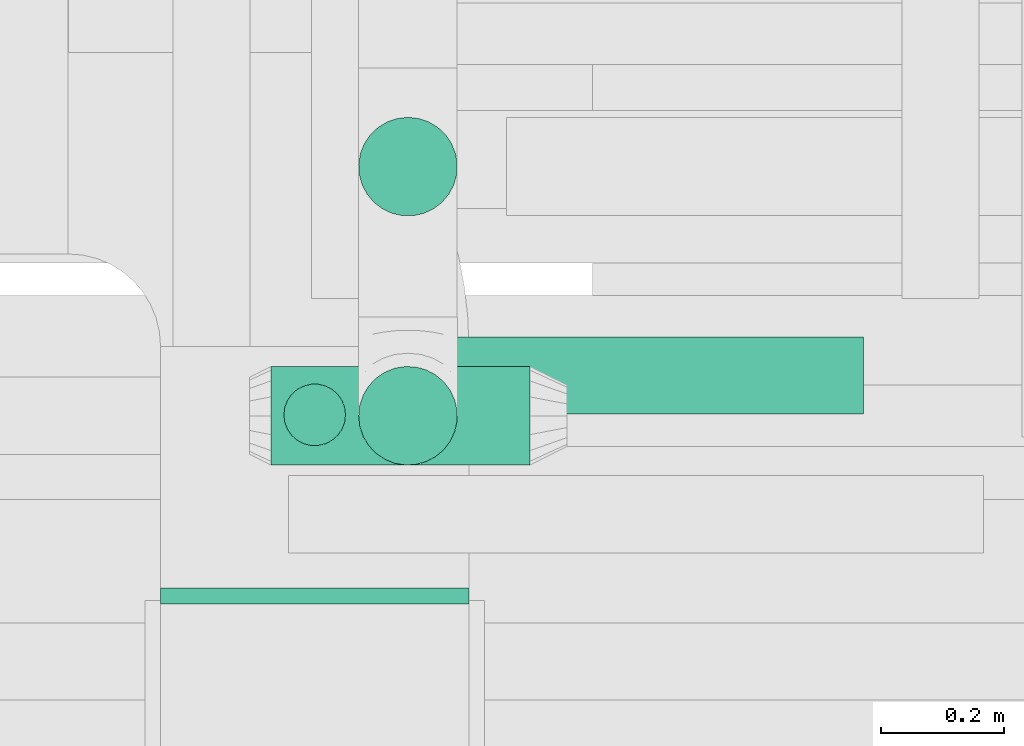
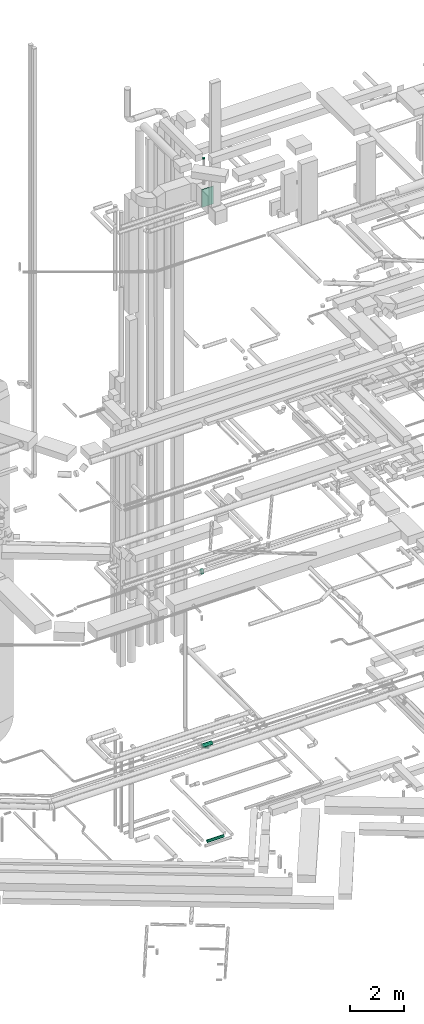
# One storey, part 99 of 337: 4 flow segments, 2 flow fittings.
"""IFC2X3 building model written with IfcOpenShell, lengths in millimetres."""

from ifc_helpers import new_model, entity, si_unit, converted_unit, derived_unit, direction, frame, origin, origin_2d_with_axis, place, context, subcontext, project, spatial, rectangle, circle, extrude, source, transform, mapped, material, type_object, type_shapes, element, save


model = new_model("IFC2X3")

# Units and contexts
model_context = context("Model", 3, precision=0.01, world=origin(), true_north=direction((6.12303176911189e-17, 1.0)))
body_context = subcontext(model_context, "Body", "Model", "MODEL_VIEW")
ifc_project = project(units=[si_unit("LENGTHUNIT", "METRE", prefix="MILLI"), si_unit("AREAUNIT", "SQUARE_METRE"), si_unit("VOLUMEUNIT", "CUBIC_METRE"), converted_unit("PLANEANGLEUNIT", "DEGREE", entity("IfcRatioMeasure", 0.0174532925199433), si_unit("PLANEANGLEUNIT", "RADIAN"), dimensions=[0, 0, 0, 0, 0, 0, 0]), si_unit("MASSUNIT", "GRAM", prefix="KILO"), derived_unit("MASSDENSITYUNIT", [(si_unit("MASSUNIT", "GRAM", prefix="KILO"), 1), (si_unit("LENGTHUNIT", "METRE"), -3)]), derived_unit("MOMENTOFINERTIAUNIT", [(si_unit("LENGTHUNIT", "METRE"), 4)]), si_unit("TIMEUNIT", "SECOND"), si_unit("FREQUENCYUNIT", "HERTZ"), si_unit("THERMODYNAMICTEMPERATUREUNIT", "DEGREE_CELSIUS"), derived_unit("THERMALTRANSMITTANCEUNIT", [(si_unit("MASSUNIT", "GRAM", prefix="KILO"), 1), (si_unit("THERMODYNAMICTEMPERATUREUNIT", "KELVIN"), -1), (si_unit("TIMEUNIT", "SECOND"), -3)]), derived_unit("VOLUMETRICFLOWRATEUNIT", [(si_unit("LENGTHUNIT", "METRE"), 3), (si_unit("TIMEUNIT", "SECOND"), -1)]), derived_unit("MASSFLOWRATEUNIT", [(si_unit("MASSUNIT", "GRAM", prefix="KILO"), 1), (si_unit("TIMEUNIT", "SECOND"), -1)]), derived_unit("ROTATIONALFREQUENCYUNIT", [(si_unit("TIMEUNIT", "SECOND"), -1)]), si_unit("ELECTRICCURRENTUNIT", "AMPERE"), si_unit("ELECTRICVOLTAGEUNIT", "VOLT"), si_unit("POWERUNIT", "WATT"), si_unit("FORCEUNIT", "NEWTON", prefix="KILO"), si_unit("ILLUMINANCEUNIT", "LUX"), si_unit("LUMINOUSFLUXUNIT", "LUMEN"), si_unit("LUMINOUSINTENSITYUNIT", "CANDELA"), derived_unit("USERDEFINED", [(si_unit("MASSUNIT", "GRAM", prefix="KILO"), -1), (si_unit("LENGTHUNIT", "METRE"), -2), (si_unit("TIMEUNIT", "SECOND"), 3), (si_unit("LUMINOUSFLUXUNIT", "LUMEN"), 1)]), derived_unit("LINEARVELOCITYUNIT", [(si_unit("LENGTHUNIT", "METRE"), 1), (si_unit("TIMEUNIT", "SECOND"), -1)]), si_unit("PRESSUREUNIT", "PASCAL"), derived_unit("USERDEFINED", [(si_unit("LENGTHUNIT", "METRE"), -2), (si_unit("MASSUNIT", "GRAM", prefix="KILO"), 1), (si_unit("TIMEUNIT", "SECOND"), -2)]), derived_unit("LINEARFORCEUNIT", [(si_unit("MASSUNIT", "GRAM", prefix="KILO"), 1), (si_unit("LENGTHUNIT", "METRE"), 1), (si_unit("TIMEUNIT", "SECOND"), -2), (si_unit("LENGTHUNIT", "METRE"), -1)]), derived_unit("PLANARFORCEUNIT", [(si_unit("MASSUNIT", "GRAM", prefix="KILO"), 1), (si_unit("LENGTHUNIT", "METRE"), 1), (si_unit("TIMEUNIT", "SECOND"), -2), (si_unit("LENGTHUNIT", "METRE"), -2)])], contexts=[model_context])

# Site, building, storey
site_placement = place(None, origin())
site = spatial("IfcSite", under=ifc_project, at=site_placement, CompositionType="ELEMENT")
building_placement = place(site_placement, origin())
building = spatial("IfcBuilding", under=site, at=building_placement, CompositionType="ELEMENT")
storey_placement = place(building_placement, origin())
storey = spatial("IfcBuildingStorey", under=building, at=storey_placement, CompositionType="ELEMENT", Elevation=0.0)

# Flow segments
duct_segment_type = type_object("IfcDuctSegmentType", PredefinedType="NOTDEFINED")
flow_segment_1_placement = place(storey_placement, frame((10556.19, 12311.66, -864.1)))
element("IfcFlowSegment", 1, at=flow_segment_1_placement, inside=storey, type_object=duct_segment_type, context=body_context, shape_type="SweptSolid", body=[
    extrude(circle(Radius=62.5, at=origin_2d_with_axis()), frame((0.0, 64.1, 64.1), z_axis=(1.0, 0.0, 0.0), x_axis=(0.0, -1.0, 0.0)), (0.0, 0.0, 1.0), 707.394973250135),
])
flow_segment_2_placement = place(storey_placement, frame((10302.78, 12228.76, 3568.4)))
element("IfcFlowSegment", 2, at=flow_segment_2_placement, inside=storey, type_object=duct_segment_type, context=body_context, shape_type="SweptSolid", body=[
    extrude(circle(Radius=80.0, at=origin_2d_with_axis()), frame((0.0, 81.6, 81.6), z_axis=(1.0, 0.0, 0.0), x_axis=(0.0, -1.0, 0.0)), (0.0, 0.0, 1.0), 419.99999999998),
])
flow_segment_3_placement = place(storey_placement, frame((10443.31, 12632.75, 11160.0)))
element("IfcFlowSegment", 3, at=flow_segment_3_placement, inside=storey, type_object=duct_segment_type, context=body_context, shape_type="SweptSolid", body=[
    extrude(circle(Radius=80.0, at=origin_2d_with_axis()), frame((81.6, 81.6, 0.0), z_axis=(0.0, 0.0, 1.0), x_axis=(0.0, 1.0, 0.0)), (0.0, 0.0, 1.0), 150.002722905561),
])
flow_segment_4_placement = place(storey_placement, frame((10443.31, 12228.76, 3480.0)))
element("IfcFlowSegment", 4, at=flow_segment_4_placement, inside=storey, type_object=duct_segment_type, context=body_context, shape_type="SweptSolid", body=[
    extrude(circle(Radius=80.0, at=origin_2d_with_axis()), frame((81.6, 81.6, 0.0), z_axis=(0.0, 0.0, 1.0), x_axis=(-1.0, 0.0, 0.0)), (0.0, 0.0, 1.0), 69.9999999999191),
])

# Flow fittings
ifc_material = material()
duct_fitting_type_1 = type_object("IfcDuctFittingType", PredefinedType="NOTDEFINED", material=ifc_material)
shared_shape_1 = source(origin(), body_context, "Body", "SweptSolid", [
    extrude(circle(Radius=49.9999999999997, at=origin_2d_with_axis()), frame((0.0, 0.0, 0.0), z_axis=(1.0, 0.0, 0.0), x_axis=(0.0, 1.0, 0.0)), (0.0, 0.0, 1.0), 25.0000000000018),
])
type_shapes(duct_fitting_type_1, [shared_shape_1])
flow_fitting_1_placement = place(storey_placement, frame((10373.64, 12311.85, 30250.0), z_axis=(0.0, -1.0, 0.0), x_axis=(0.0, 0.0, 1.0)))
element("IfcFlowFitting", 5, at=flow_fitting_1_placement, inside=storey, type_object=duct_fitting_type_1, material=ifc_material, context=body_context, shape_type="MappedRepresentation", body=[
    mapped(shared_shape_1, transform((0.0, 0.0, 0.0), scale=1.0)),
])
duct_fitting_type_2 = type_object("IfcDuctFittingType", PredefinedType="NOTDEFINED", material=ifc_material)
shared_shape_2 = source(origin(), body_context, "Body", "SweptSolid", [
    extrude(rectangle(XDim=500.0, YDim=26.0960000000953, at=origin_2d_with_axis()), frame((6.95, 0.0, -400.0), z_axis=(0.0, 0.0, 1.0), x_axis=(0.0, -1.0, 0.0)), (0.0, 0.0, 1.0), 800.0),
])
type_shapes(duct_fitting_type_2, [shared_shape_2])
flow_fitting_2_placement = place(storey_placement, frame((10373.64, 12011.11, 28700.0), z_axis=(0.0, 0.0, -1.0), x_axis=(0.0, 1.0, 0.0)))
element("IfcFlowFitting", 6, at=flow_fitting_2_placement, inside=storey, type_object=duct_fitting_type_2, material=ifc_material, context=body_context, shape_type="MappedRepresentation", body=[
    mapped(shared_shape_2, transform((0.0, 0.0, 0.0), scale=1.0)),
])

save(model, "model.ifc")
